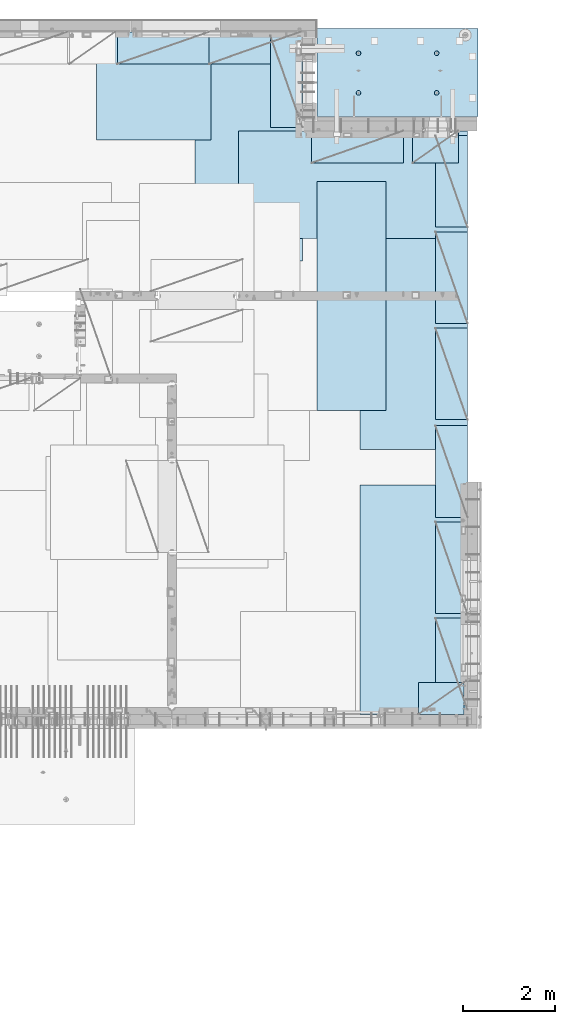
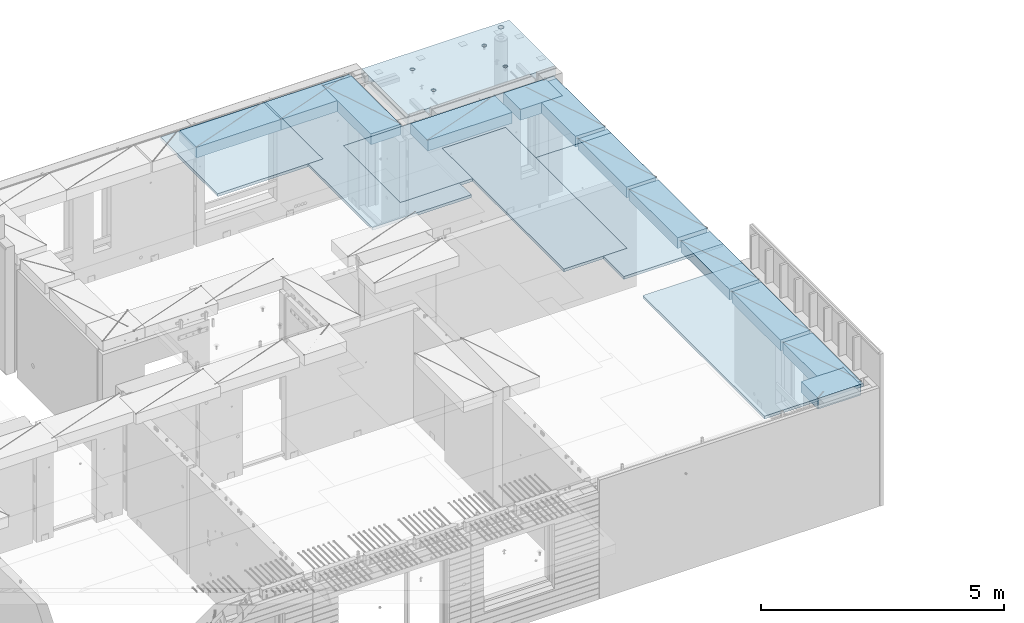
# One storey, part 179 of 309: 18 plates, 1 slab, 19 elements without a shape of their own.
"""IFC2X3 building model written with IfcOpenShell, lengths in millimetres."""

from ifc_helpers import new_model, si_unit, frame, origin_with_axes, place, context, subcontext, project, spatial, faceted_brep, material, type_object, element, aggregate, save


model = new_model("IFC2X3")

# Units and contexts
model_context = context("Model", 3, precision=1e-05, world=origin_with_axes())
body_context = subcontext(model_context, "Body", "Model", "MODEL_VIEW")
ifc_project = project(units=[si_unit("LENGTHUNIT", "METRE", prefix="MILLI"), si_unit("AREAUNIT", "SQUARE_METRE"), si_unit("VOLUMEUNIT", "CUBIC_METRE"), si_unit("MASSUNIT", "GRAM", prefix="KILO"), si_unit("TIMEUNIT", "SECOND"), si_unit("PLANEANGLEUNIT", "RADIAN"), si_unit("SOLIDANGLEUNIT", "STERADIAN"), si_unit("THERMODYNAMICTEMPERATUREUNIT", "DEGREE_CELSIUS"), si_unit("LUMINOUSINTENSITYUNIT", "LUMEN")], contexts=[model_context])

# Site, building, storey
site_placement = place(None, origin_with_axes())
site = spatial("IfcSite", under=ifc_project, at=site_placement, CompositionType="ELEMENT")
building_placement = place(site_placement, origin_with_axes())
building = spatial("IfcBuilding", under=site, at=building_placement, CompositionType="ELEMENT")
storey_placement = place(building_placement, origin_with_axes())
storey = spatial("IfcBuildingStorey", under=building, at=storey_placement, Name="7", CompositionType="ELEMENT", Elevation=0.0)

# Assembly, plate
assembly_1_placement = place(storey_placement, origin_with_axes())
assembly_1 = element("IfcElementAssembly", 1, at=assembly_1_placement, inside=storey, Name="Steel Assembly", AssemblyPlace="NOTDEFINED", PredefinedType="NOTDEFINED")
ifc_material_1 = material()
plate_type_1 = type_object("IfcPlateType", PredefinedType="NOTDEFINED")
plate_1_placement = place(assembly_1_placement, frame((26960.07, 22728.45, 102695.1), z_axis=(1.0, 0.0, 0.0), x_axis=(0.0, -1.0, 0.0)))
plate_1 = element("IfcPlate", 2, at=plate_1_placement, type_object=plate_type_1, material=ifc_material_1, Name="1/2", context=body_context, shape_type="Brep", body=[
    faceted_brep([(0.0, -35.0, 0.0), (0.0, -35.0, 2500.0), (0.0, 35.0, 2500.0), (0.0, 35.0, 0.0), (2349.99951171875, -35.0, 2500.0), (2349.99951171875, 35.0, 2500.0), (2350.0, -35.0, 0.0), (2350.0, 35.0, 0.0)], [[[0, 1, 2, 3]], [[1, 4, 5, 2]], [[4, 6, 7, 5]], [[6, 0, 3, 7]], [[5, 7, 3, 2]], [[6, 4, 1, 0]]]),
])
aggregate(assembly_1, [plate_1])

assembly_2_placement = place(storey_placement, origin_with_axes())
assembly_2 = element("IfcElementAssembly", 3, at=assembly_2_placement, inside=storey, Name="Steel Assembly", AssemblyPlace="NOTDEFINED", PredefinedType="NOTDEFINED")
plate_2_placement = place(assembly_2_placement, frame((31460.0, 22740.0, 102695.1), z_axis=(0.0, -1.0, 0.0), x_axis=(-1.0, 3.00000001838171e-08, 0.0)))
plate_2 = element("IfcPlate", 4, at=plate_2_placement, type_object=plate_type_1, material=ifc_material_1, context=body_context, shape_type="Brep", body=[
    faceted_brep([(0.0, -35.0, 0.0), (0.0, -35.0, 5000.0), (0.0, 35.0, 5000.0), (0.0, 35.0, 0.0), (2349.99951171875, -35.0, 5000.0), (2349.99951171875, 35.0, 5000.0), (2350.0, -35.0, 0.0), (2350.0, 35.0, 0.0)], [[[0, 1, 2, 3]], [[1, 4, 5, 2]], [[4, 6, 7, 5]], [[6, 0, 3, 7]], [[5, 7, 3, 2]], [[6, 4, 1, 0]]]),
])
aggregate(assembly_2, [plate_2])

assembly_3_placement = place(storey_placement, origin_with_axes())
assembly_3 = element("IfcElementAssembly", 5, at=assembly_3_placement, inside=storey, Name="Steel Assembly", AssemblyPlace="NOTDEFINED", PredefinedType="NOTDEFINED")
plate_3_placement = place(assembly_3_placement, frame((35060.0, 12850.0, 102695.1), z_axis=(0.0, -1.0, 0.0), x_axis=(-1.0, 3.00000001838171e-08, 0.0)))
plate_3 = element("IfcPlate", 6, at=plate_3_placement, type_object=plate_type_1, material=ifc_material_1, context=body_context, shape_type="Brep", body=[
    faceted_brep([(0.0, -35.0, 0.0), (0.0, -35.0, 5000.0), (0.0, 35.0, 5000.0), (0.0, 35.0, 0.0), (2349.99951171875, -35.0, 5000.0), (2349.99951171875, 35.0, 5000.0), (2350.0, -35.0, 0.0), (2350.0, 35.0, 0.0)], [[[0, 1, 2, 3]], [[1, 4, 5, 2]], [[4, 6, 7, 5]], [[6, 0, 3, 7]], [[5, 7, 3, 2]], [[6, 4, 1, 0]]]),
])
aggregate(assembly_3, [plate_3])

assembly_4_placement = place(storey_placement, origin_with_axes())
assembly_4 = element("IfcElementAssembly", 7, at=assembly_4_placement, inside=storey, Name="Steel Assembly", AssemblyPlace="NOTDEFINED", PredefinedType="NOTDEFINED")
plate_4_placement = place(assembly_4_placement, frame((35060.0, 18630.0, 102695.1), z_axis=(0.0, -1.0, 0.0), x_axis=(-1.0, 3.00000001838171e-08, 0.0)))
plate_4 = element("IfcPlate", 8, at=plate_4_placement, type_object=plate_type_1, material=ifc_material_1, context=body_context, shape_type="Brep", body=[
    faceted_brep([(0.0, -35.0, 0.0), (0.0, -35.0, 5000.0), (0.0, 35.0, 5000.0), (0.0, 35.0, 0.0), (2349.99951171875, -35.0, 5000.0), (2349.99951171875, 35.0, 5000.0), (2350.0, -35.0, 0.0), (2350.0, 35.0, 0.0)], [[[0, 1, 2, 3]], [[1, 4, 5, 2]], [[4, 6, 7, 5]], [[6, 0, 3, 7]], [[5, 7, 3, 2]], [[6, 4, 1, 0]]]),
])
aggregate(assembly_4, [plate_4])

assembly_5_placement = place(storey_placement, origin_with_axes())
assembly_5 = element("IfcElementAssembly", 9, at=assembly_5_placement, inside=storey, Name="Steel Assembly", AssemblyPlace="NOTDEFINED", PredefinedType="NOTDEFINED")
plate_5_placement = place(assembly_5_placement, frame((30060.0, 20580.0, 102695.1), z_axis=(1.0, 0.0, 0.0), x_axis=(0.0, -1.0, 0.0)))
plate_5 = element("IfcPlate", 10, at=plate_5_placement, type_object=plate_type_1, material=ifc_material_1, context=body_context, shape_type="Brep", body=[
    faceted_brep([(0.0, -35.0, 0.0), (0.0, -35.0, 5000.0), (0.0, 35.0, 5000.0), (0.0, 35.0, 0.0), (2349.99951171875, -35.0, 5000.0), (2349.99951171875, 35.0, 5000.0), (2350.0, -35.0, 0.0), (2350.0, 35.0, 0.0)], [[[0, 1, 2, 3]], [[1, 4, 5, 2]], [[4, 6, 7, 5]], [[6, 0, 3, 7]], [[5, 7, 3, 2]], [[6, 4, 1, 0]]]),
])
aggregate(assembly_5, [plate_5])

assembly_6_placement = place(storey_placement, origin_with_axes())
assembly_6 = element("IfcElementAssembly", 11, at=assembly_6_placement, inside=storey, Name="Steel Assembly", AssemblyPlace="NOTDEFINED", PredefinedType="NOTDEFINED")
plate_type_2 = type_object("IfcPlateType", PredefinedType="NOTDEFINED")
plate_6_placement = place(assembly_6_placement, frame((33275.0000122641, 19480.0, 102695.100000381), z_axis=(0.0, -1.0, 0.0), x_axis=(-1.0, 3.00000001838171e-08, 0.0)))
plate_6 = element("IfcPlate", 12, at=plate_6_placement, type_object=plate_type_2, material=ifc_material_1, context=body_context, shape_type="Brep", body=[
    faceted_brep([(0.0, -35.0, 0.0), (0.0, -35.0, 5000.0), (0.0, 35.0, 5000.0), (0.0, 35.0, 0.0), (1499.99951171875, -35.0, 5000.0), (1499.99951171875, 35.0, 5000.0), (1500.0, -35.0, 0.0), (1500.0, 35.0, 0.0)], [[[0, 1, 2, 3]], [[1, 4, 5, 2]], [[4, 6, 7, 5]], [[6, 0, 3, 7]], [[5, 7, 3, 2]], [[6, 4, 1, 0]]]),
])
aggregate(assembly_6, [plate_6])

assembly_7_placement = place(storey_placement, origin_with_axes())
assembly_7 = element("IfcElementAssembly", 13, at=assembly_7_placement, inside=storey, Name="Steel Assembly", AssemblyPlace="NOTDEFINED", PredefinedType="NOTDEFINED")
plate_type_3 = type_object("IfcPlateType", PredefinedType="NOTDEFINED")
plate_7_placement = place(assembly_7_placement, frame((31420.0, 22740.0001220703, 102595.3), z_axis=(0.0, -1.0, 0.0), x_axis=(-1.0, 3.00000001838171e-08, 0.0)))
plate_7 = element("IfcPlate", 14, at=plate_7_placement, type_object=plate_type_3, material=ifc_material_1, Name="RE1", context=body_context, shape_type="Brep", body=[
    faceted_brep([(1.81898940354586e-12, -135.0, 1.81898940354586e-12), (0.0, -135.0, 699.999999999996), (0.0, 135.0, 699.999999999996), (1.81898940354586e-12, 135.0, 1.81898940354586e-12), (1999.99951171875, -135.0, 699.999999999993), (1999.99951171875, 135.0, 699.999999999993), (2000.0, -135.0, -3.63797880709171e-12), (2000.0, 135.0, -3.63797880709171e-12)], [[[0, 1, 2, 3]], [[1, 4, 5, 2]], [[4, 6, 7, 5]], [[6, 0, 3, 7]], [[5, 7, 3, 2]], [[6, 4, 1, 0]]]),
])
aggregate(assembly_7, [plate_7])

assembly_8_placement = place(storey_placement, origin_with_axes())
assembly_8 = element("IfcElementAssembly", 15, at=assembly_8_placement, inside=storey, Name="Steel Assembly", AssemblyPlace="NOTDEFINED", PredefinedType="NOTDEFINED")
plate_8_placement = place(assembly_8_placement, frame((33985.0, 7849.99999992931, 102595.3), z_axis=(0.0, 1.0, 0.0), x_axis=(1.0, 0.0, 0.0)))
plate_8 = element("IfcPlate", 16, at=plate_8_placement, type_object=plate_type_3, material=ifc_material_1, Name="RE1_1/2", context=body_context, shape_type="Brep", body=[
    faceted_brep([(1.81898940354586e-12, -135.0, 1.81898940354586e-12), (0.0, -135.0, 699.999999999996), (0.0, 135.0, 699.999999999996), (1.81898940354586e-12, 135.0, 1.81898940354586e-12), (999.99951171875, -135.0, 700.0), (999.99951171875, 135.0, 700.0), (1000.0, -135.0, 0.0), (1000.0, 135.0, 0.0)], [[[0, 1, 2, 3]], [[1, 4, 5, 2]], [[4, 6, 7, 5]], [[6, 0, 3, 7]], [[5, 7, 3, 2]], [[6, 4, 1, 0]]]),
])
aggregate(assembly_8, [plate_8])

assembly_9_placement = place(storey_placement, origin_with_axes())
assembly_9 = element("IfcElementAssembly", 17, at=assembly_9_placement, inside=storey, Name="Steel Assembly", AssemblyPlace="NOTDEFINED", PredefinedType="NOTDEFINED")
plate_9_placement = place(assembly_9_placement, frame((35060.0001220703, 14280.0, 102595.3), z_axis=(-1.0, 3.00000001838171e-08, 0.0), x_axis=(0.0, 1.0, 0.0)))
plate_9 = element("IfcPlate", 18, at=plate_9_placement, type_object=plate_type_3, material=ifc_material_1, Name="RE1", context=body_context, shape_type="Brep", body=[
    faceted_brep([(1.81898940354586e-12, -135.0, 1.81898940354586e-12), (0.0, -135.0, 699.999999999996), (0.0, 135.0, 699.999999999996), (1.81898940354586e-12, 135.0, 1.81898940354586e-12), (1999.99951171875, -135.0, 699.999999999993), (1999.99951171875, 135.0, 699.999999999993), (2000.0, -135.0, -3.63797880709171e-12), (2000.0, 135.0, -3.63797880709171e-12)], [[[0, 1, 2, 3]], [[1, 4, 5, 2]], [[4, 6, 7, 5]], [[6, 0, 3, 7]], [[5, 7, 3, 2]], [[6, 4, 1, 0]]]),
])
aggregate(assembly_9, [plate_9])

assembly_10_placement = place(storey_placement, origin_with_axes())
assembly_10 = element("IfcElementAssembly", 19, at=assembly_10_placement, inside=storey, Name="Steel Assembly", AssemblyPlace="NOTDEFINED", PredefinedType="NOTDEFINED")
plate_10_placement = place(assembly_10_placement, frame((35060.0001220703, 16380.0, 102595.3), z_axis=(-1.0, 3.00000001838171e-08, 0.0), x_axis=(0.0, 1.0, 0.0)))
plate_10 = element("IfcPlate", 20, at=plate_10_placement, type_object=plate_type_3, material=ifc_material_1, Name="RE1", context=body_context, shape_type="Brep", body=[
    faceted_brep([(1.81898940354586e-12, -135.0, 1.81898940354586e-12), (0.0, -135.0, 699.999999999996), (0.0, 135.0, 699.999999999996), (1.81898940354586e-12, 135.0, 1.81898940354586e-12), (1999.99951171875, -135.0, 699.999999999993), (1999.99951171875, 135.0, 699.999999999993), (2000.0, -135.0, -3.63797880709171e-12), (2000.0, 135.0, -3.63797880709171e-12)], [[[0, 1, 2, 3]], [[1, 4, 5, 2]], [[4, 6, 7, 5]], [[6, 0, 3, 7]], [[5, 7, 3, 2]], [[6, 4, 1, 0]]]),
])
aggregate(assembly_10, [plate_10])

assembly_11_placement = place(storey_placement, origin_with_axes())
assembly_11 = element("IfcElementAssembly", 21, at=assembly_11_placement, inside=storey, Name="Steel Assembly", AssemblyPlace="NOTDEFINED", PredefinedType="NOTDEFINED")
plate_11_placement = place(assembly_11_placement, frame((35060.0001220703, 18480.0, 102595.3), z_axis=(-1.0, 3.00000001838171e-08, 0.0), x_axis=(0.0, 1.0, 0.0)))
plate_11 = element("IfcPlate", 22, at=plate_11_placement, type_object=plate_type_3, material=ifc_material_1, Name="RE1", context=body_context, shape_type="Brep", body=[
    faceted_brep([(1.81898940354586e-12, -135.0, 1.81898940354586e-12), (0.0, -135.0, 699.999999999996), (0.0, 135.0, 699.999999999996), (1.81898940354586e-12, 135.0, 1.81898940354586e-12), (1999.99951171875, -135.0, 699.999999999993), (1999.99951171875, 135.0, 699.999999999993), (2000.0, -135.0, -3.63797880709171e-12), (2000.0, 135.0, -3.63797880709171e-12)], [[[0, 1, 2, 3]], [[1, 4, 5, 2]], [[4, 6, 7, 5]], [[6, 0, 3, 7]], [[5, 7, 3, 2]], [[6, 4, 1, 0]]]),
])
aggregate(assembly_11, [plate_11])

assembly_12_placement = place(storey_placement, origin_with_axes())
assembly_12 = element("IfcElementAssembly", 23, at=assembly_12_placement, inside=storey, Name="Steel Assembly", AssemblyPlace="NOTDEFINED", PredefinedType="NOTDEFINED")
plate_12_placement = place(assembly_12_placement, frame((35060.0001220703, 12150.0, 102595.3), z_axis=(-1.0, 3.00000001838171e-08, 0.0), x_axis=(0.0, 1.0, 0.0)))
plate_12 = element("IfcPlate", 24, at=plate_12_placement, type_object=plate_type_3, material=ifc_material_1, Name="RE1", context=body_context, shape_type="Brep", body=[
    faceted_brep([(1.81898940354586e-12, -135.0, 1.81898940354586e-12), (0.0, -135.0, 699.999999999996), (0.0, 135.0, 699.999999999996), (1.81898940354586e-12, 135.0, 1.81898940354586e-12), (1999.99951171875, -135.0, 699.999999999993), (1999.99951171875, 135.0, 699.999999999993), (2000.0, -135.0, -3.63797880709171e-12), (2000.0, 135.0, -3.63797880709171e-12)], [[[0, 1, 2, 3]], [[1, 4, 5, 2]], [[4, 6, 7, 5]], [[6, 0, 3, 7]], [[5, 7, 3, 2]], [[6, 4, 1, 0]]]),
])
aggregate(assembly_12, [plate_12])

assembly_13_placement = place(storey_placement, origin_with_axes())
assembly_13 = element("IfcElementAssembly", 25, at=assembly_13_placement, inside=storey, Name="Steel Assembly", AssemblyPlace="NOTDEFINED", PredefinedType="NOTDEFINED")
plate_13_placement = place(assembly_13_placement, frame((35060.0001220703, 10050.0, 102595.3), z_axis=(-1.0, 3.00000001838171e-08, 0.0), x_axis=(0.0, 1.0, 0.0)))
plate_13 = element("IfcPlate", 26, at=plate_13_placement, type_object=plate_type_3, material=ifc_material_1, Name="RE1", context=body_context, shape_type="Brep", body=[
    faceted_brep([(1.81898940354586e-12, -135.0, 1.81898940354586e-12), (0.0, -135.0, 699.999999999996), (0.0, 135.0, 699.999999999996), (1.81898940354586e-12, 135.0, 1.81898940354586e-12), (1999.99951171875, -135.0, 699.999999999993), (1999.99951171875, 135.0, 699.999999999993), (2000.0, -135.0, -3.63797880709171e-12), (2000.0, 135.0, -3.63797880709171e-12)], [[[0, 1, 2, 3]], [[1, 4, 5, 2]], [[4, 6, 7, 5]], [[6, 0, 3, 7]], [[5, 7, 3, 2]], [[6, 4, 1, 0]]]),
])
aggregate(assembly_13, [plate_13])

assembly_14_placement = place(storey_placement, origin_with_axes())
assembly_14 = element("IfcElementAssembly", 27, at=assembly_14_placement, inside=storey, Name="Steel Assembly", AssemblyPlace="NOTDEFINED", PredefinedType="NOTDEFINED")
plate_14_placement = place(assembly_14_placement, frame((35060.0001220703, 7950.0, 102595.3), z_axis=(-1.0, 3.00000001838171e-08, 0.0), x_axis=(0.0, 1.0, 0.0)))
plate_14 = element("IfcPlate", 28, at=plate_14_placement, type_object=plate_type_3, material=ifc_material_1, Name="RE1", context=body_context, shape_type="Brep", body=[
    faceted_brep([(1.81898940354586e-12, -135.0, 1.81898940354586e-12), (0.0, -135.0, 699.999999999996), (0.0, 135.0, 699.999999999996), (1.81898940354586e-12, 135.0, 1.81898940354586e-12), (1999.99951171875, -135.0, 699.999999999993), (1999.99951171875, 135.0, 699.999999999993), (2000.0, -135.0, -3.63797880709171e-12), (2000.0, 135.0, -3.63797880709171e-12)], [[[0, 1, 2, 3]], [[1, 4, 5, 2]], [[4, 6, 7, 5]], [[6, 0, 3, 7]], [[5, 7, 3, 2]], [[6, 4, 1, 0]]]),
])
aggregate(assembly_14, [plate_14])

assembly_15_placement = place(storey_placement, origin_with_axes())
assembly_15 = element("IfcElementAssembly", 29, at=assembly_15_placement, inside=storey, Name="Steel Assembly", AssemblyPlace="NOTDEFINED", PredefinedType="NOTDEFINED")
plate_15_placement = place(assembly_15_placement, frame((33660.0, 20580.0001220703, 102595.3), z_axis=(0.0, -1.0, 0.0), x_axis=(-1.0, 3.00000001838171e-08, 0.0)))
plate_15 = element("IfcPlate", 30, at=plate_15_placement, type_object=plate_type_3, material=ifc_material_1, Name="RE1", context=body_context, shape_type="Brep", body=[
    faceted_brep([(1.81898940354586e-12, -135.0, 1.81898940354586e-12), (0.0, -135.0, 699.999999999996), (0.0, 135.0, 699.999999999996), (1.81898940354586e-12, 135.0, 1.81898940354586e-12), (1999.99951171875, -135.0, 699.999999999993), (1999.99951171875, 135.0, 699.999999999993), (2000.0, -135.0, -3.63797880709171e-12), (2000.0, 135.0, -3.63797880709171e-12)], [[[0, 1, 2, 3]], [[1, 4, 5, 2]], [[4, 6, 7, 5]], [[6, 0, 3, 7]], [[5, 7, 3, 2]], [[6, 4, 1, 0]]]),
])
aggregate(assembly_15, [plate_15])

assembly_16_placement = place(storey_placement, origin_with_axes())
assembly_16 = element("IfcElementAssembly", 31, at=assembly_16_placement, inside=storey, Name="Steel Assembly", AssemblyPlace="NOTDEFINED", PredefinedType="NOTDEFINED")
plate_16_placement = place(assembly_16_placement, frame((34860.0, 20580.0000000707, 102595.3), z_axis=(0.0, -1.0, 0.0), x_axis=(-1.0, 3.00000001838171e-08, 0.0)))
plate_16 = element("IfcPlate", 32, at=plate_16_placement, type_object=plate_type_3, material=ifc_material_1, Name="RE1_1/2", context=body_context, shape_type="Brep", body=[
    faceted_brep([(1.81898940354586e-12, -135.0, 1.81898940354586e-12), (0.0, -135.0, 699.999999999996), (0.0, 135.0, 699.999999999996), (1.81898940354586e-12, 135.0, 1.81898940354586e-12), (999.99951171875, -135.0, 700.0), (999.99951171875, 135.0, 700.0), (1000.0, -135.0, 0.0), (1000.0, 135.0, 0.0)], [[[0, 1, 2, 3]], [[1, 4, 5, 2]], [[4, 6, 7, 5]], [[6, 0, 3, 7]], [[5, 7, 3, 2]], [[6, 4, 1, 0]]]),
])
aggregate(assembly_16, [plate_16])

assembly_17_placement = place(storey_placement, origin_with_axes())
assembly_17 = element("IfcElementAssembly", 33, at=assembly_17_placement, inside=storey, Name="Steel Assembly", AssemblyPlace="NOTDEFINED", PredefinedType="NOTDEFINED")
plate_17_placement = place(assembly_17_placement, frame((31460.0001220703, 20660.0, 102595.3), z_axis=(-1.0, 3.00000001838171e-08, 0.0), x_axis=(0.0, 1.0, 0.0)))
plate_17 = element("IfcPlate", 34, at=plate_17_placement, type_object=plate_type_3, material=ifc_material_1, Name="RE1", context=body_context, shape_type="Brep", body=[
    faceted_brep([(1.81898940354586e-12, -135.0, 1.81898940354586e-12), (0.0, -135.0, 699.999999999996), (0.0, 135.0, 699.999999999996), (1.81898940354586e-12, 135.0, 1.81898940354586e-12), (1999.99951171875, -135.0, 699.999999999993), (1999.99951171875, 135.0, 699.999999999993), (2000.0, -135.0, -3.63797880709171e-12), (2000.0, 135.0, -3.63797880709171e-12)], [[[0, 1, 2, 3]], [[1, 4, 5, 2]], [[4, 6, 7, 5]], [[6, 0, 3, 7]], [[5, 7, 3, 2]], [[6, 4, 1, 0]]]),
])
aggregate(assembly_17, [plate_17])

assembly_18_placement = place(storey_placement, origin_with_axes())
assembly_18 = element("IfcElementAssembly", 35, at=assembly_18_placement, inside=storey, Name="Steel Assembly", AssemblyPlace="NOTDEFINED", PredefinedType="NOTDEFINED")
plate_18_placement = place(assembly_18_placement, frame((29420.0, 22740.0001220703, 102595.3), z_axis=(0.0, -1.0, 0.0), x_axis=(-1.0, 3.00000001838171e-08, 0.0)))
plate_18 = element("IfcPlate", 36, at=plate_18_placement, type_object=plate_type_3, material=ifc_material_1, Name="RE1", context=body_context, shape_type="Brep", body=[
    faceted_brep([(1.81898940354586e-12, -135.0, 1.81898940354586e-12), (0.0, -135.0, 699.999999999996), (0.0, 135.0, 699.999999999996), (1.81898940354586e-12, 135.0, 1.81898940354586e-12), (1999.99951171875, -135.0, 699.999999999993), (1999.99951171875, 135.0, 699.999999999993), (2000.0, -135.0, -3.63797880709171e-12), (2000.0, 135.0, -3.63797880709171e-12)], [[[0, 1, 2, 3]], [[1, 4, 5, 2]], [[4, 6, 7, 5]], [[6, 0, 3, 7]], [[5, 7, 3, 2]], [[6, 4, 1, 0]]]),
])
aggregate(assembly_18, [plate_18])

# Assembly, slab
assembly_19_placement = place(storey_placement, origin_with_axes())
assembly_19 = element("IfcElementAssembly", 37, at=assembly_19_placement, inside=storey, AssemblyPlace="NOTDEFINED", PredefinedType="REINFORCEMENT_UNIT")
ifc_material_2 = material(Name="CONCRETE/C35/45")
slab_type = type_object("IfcSlabType", PredefinedType="NOTDEFINED")
slab_placement = place(assembly_19_placement, frame((31779.9998568132, 20899.9965573523, 102575.0), z_axis=(-1.19799915409591e-06, 0.999999999999282, 0.0), x_axis=(0.999999999999282, 1.19800000174933e-06, 0.0)))
slab = element("IfcSlab", 38, at=slab_placement, type_object=slab_type, material=ifc_material_2, PredefinedType="FLOOR", context=body_context, shape_type="Brep", body=[
    faceted_brep([(2620.44345679515, -110.0, 1327.44477430751), (2634.38188363927, -110.0, 1334.54672302846), (2645.44349246833, -110.0, 1345.6082884076), (2652.54549593937, -110.0, 1359.54668735517), (2654.99270047008, -110.0, 1374.99753226764), (2652.54555663031, -110.0, 1390.44838679261), (2645.44360790936, -110.0, 1404.38681363673), (2634.38204253021, -110.0, 1415.4484224658), (2620.44364358264, -110.0, 1422.55042593684), (2604.99279867017, -110.0, 1424.99763046754), (2589.5419441452, -110.0, 1422.55048662777), (2575.60351730108, -110.0, 1415.44853790682), (2564.54190847202, -110.0, 1404.38697252767), (2557.43990500097, -110.0, 1390.44857358011), (2554.99270047027, -110.0, 1374.99772866764), (2557.43984431004, -110.0, 1359.54687414267), (2564.54179303099, -110.0, 1345.60844729854), (2575.60335841014, -110.0, 1334.54683846948), (2589.54175735771, -110.0, 1327.44483499845), (2604.99260227018, -110.0, 1324.99763046774), (2646.40672475315, -130.0, 1405.08655609315), (2653.67776749127, -130.0, 1390.8162619432), (2635.08178876973, -130.0, 1416.41153656099), (2620.81152318056, -130.0, 1423.68263535277), (2604.99280100827, -130.0, 1426.18810665802), (2589.17406899461, -130.0, 1423.68269748873), (2574.90377484467, -130.0, 1416.41165475061), (2563.57879437682, -130.0, 1405.0867187672), (2556.30769558505, -130.0, 1390.81645317802), (2553.8022242798, -130.0, 1374.99773100574), (2556.30763344908, -130.0, 1359.17899899208), (2563.5786761872, -130.0, 1344.90870484214), (2574.90361217062, -130.0, 1333.58372437429), (2589.17387775979, -130.0, 1326.31262558251), (2604.99259993208, -130.0, 1323.80715427726), (2620.81133194574, -130.0, 1326.31256344655), (2635.08162609568, -130.0, 1333.58360618467), (2646.40660656353, -130.0, 1344.90854216808), (2653.6777053553, -130.0, 1359.17880775726), (2656.18317666055, -130.0, 1374.99752992954), (3505.0, -130.0, 1.02227204479277e-09), (0.0, -130.0, -3.63797880709171e-12), (0.0, 130.0, -1.81898940354586e-12), (3505.0, 130.0, 1.02227204479277e-09), (3505.0, -130.0, 1910.00366210938), (3505.0, 130.0, 1910.00366210938), (0.000373178780137096, -130.0, 1910.00366210938), (0.000373178780137096, 130.0, 1910.00366210938), (3278.54350360826, 130.0, 1805.26900756737), (3265.26962515329, 130.0, 1818.54293816225), (3248.54354641621, 130.0, 1827.0653423275), (3230.00253252125, 130.0, 1830.00198776434), (3211.46150709129, 130.0, 1827.06541515662), (3194.73539487833, 130.0, 1818.54307669148), (3181.46146428346, 130.0, 1805.2691982365), (3172.93906011821, 130.0, 1788.54311949942), (3170.00241468137, 130.0, 1770.00210560446), (3172.93898728908, 130.0, 1751.4610801745), (3181.46132575424, 130.0, 1734.73496796154), (3194.73520420921, 130.0, 1721.46103736667), (3211.46128294629, 130.0, 1712.93863320142), (3230.00229684125, 130.0, 1710.00198776457), (3248.54332227121, 130.0, 1712.93856037229), (3265.26943448417, 130.0, 1721.46089883744), (3278.54336507904, 130.0, 1734.73477729241), (3287.06576924428, 130.0, 1751.46085602949), (3290.00241468113, 130.0, 1770.00186992446), (3287.06584207341, 130.0, 1788.54289535442), (3287.06584207341, -130.0, 1788.54289535442), (3290.00241468113, -130.0, 1770.00186992446), (3278.54350360826, -130.0, 1805.26900756737), (3265.26962515329, -130.0, 1818.54293816225), (3248.54354641621, -130.0, 1827.0653423275), (3230.00253252125, -130.0, 1830.00198776434), (3211.46150709129, -130.0, 1827.06541515662), (3194.73539487833, -130.0, 1818.54307669148), (3181.46146428346, -130.0, 1805.2691982365), (3172.93906011821, -130.0, 1788.54311949942), (3170.00241468137, -130.0, 1770.00210560446), (3172.93898728908, -130.0, 1751.4610801745), (3181.46132575424, -130.0, 1734.73496796154), (3194.73520420921, -130.0, 1721.46103736667), (3211.46128294629, -130.0, 1712.93863320142), (3230.00229684125, -130.0, 1710.00198776457), (3248.54332227121, -130.0, 1712.93856037229), (3265.26943448417, -130.0, 1721.46089883744), (3278.54336507904, -130.0, 1734.73477729241), (3287.06576924428, -130.0, 1751.46085602949), (915.443456827416, -110.0, 1327.44812283643), (929.381883671544, -110.0, 1334.55007155738), (940.443492500606, -110.0, 1345.61163693653), (947.545495971644, -110.0, 1359.55003588409), (949.992700502353, -110.0, 1375.00088079656), (947.545556662582, -110.0, 1390.45173532153), (940.44360794163, -110.0, 1404.39016216566), (929.382042562484, -110.0, 1415.45177099472), (915.443643614915, -110.0, 1422.55377446576), (899.992798702449, -110.0, 1425.00097899646), (884.541944177479, -110.0, 1422.55383515669), (870.603517333351, -110.0, 1415.45188643575), (859.541908504289, -110.0, 1404.3903210566), (852.439905033254, -110.0, 1390.45192210903), (849.992700502546, -110.0, 1375.00107719656), (852.439844342316, -110.0, 1359.55022267159), (859.541793063265, -110.0, 1345.61179582746), (870.603358442411, -110.0, 1334.5501869984), (884.541757389979, -110.0, 1327.44818352737), (899.992602302449, -110.0, 1325.00097899666), (948.677767523539, -130.0, 1390.81961047212), (951.18317669283, -130.0, 1375.00087845847), (941.406724785422, -130.0, 1405.08990462207), (930.08178880201, -130.0, 1416.41488508992), (915.811523212829, -130.0, 1423.68598388169), (899.992801040546, -130.0, 1426.19145518694), (884.174069026885, -130.0, 1423.68604601765), (869.903774876948, -130.0, 1416.41500327954), (858.578794409095, -130.0, 1405.09006729612), (851.307695617317, -130.0, 1390.81980170694), (848.802224312072, -130.0, 1375.00107953466), (851.307633481356, -130.0, 1359.182347521), (858.578676219477, -130.0, 1344.91205337106), (869.903612202892, -130.0, 1333.58707290321), (884.173877792065, -130.0, 1326.31597411143), (899.992599964353, -130.0, 1323.81050280618), (915.81133197801, -130.0, 1326.31591197547), (930.081626127954, -130.0, 1333.58695471359), (941.406606595803, -130.0, 1344.911890697), (948.677705387578, -130.0, 1359.18215628618), (915.441758004057, -110.0, 462.456291784572), (929.380184848189, -110.0, 469.558240505528), (940.441793677252, -110.0, 480.619805884675), (947.543797148286, -110.0, 494.558204832239), (949.991001678995, -110.0, 510.009049744709), (947.543857839224, -110.0, 525.459904269679), (940.441909118272, -110.0, 539.398331113807), (929.380343739125, -110.0, 550.45993994287), (915.441944791557, -110.0, 557.561943413904), (899.991099879091, -110.0, 560.009147944613), (884.540245354121, -110.0, 557.562004104842), (870.601818509993, -110.0, 550.460055383894), (859.54020968093, -110.0, 539.398490004744), (852.438206209896, -110.0, 525.460091057179), (849.991001679187, -110.0, 510.009246144709), (852.438145518958, -110.0, 494.558391619739), (859.54009423991, -110.0, 480.619964775611), (870.601659619057, -110.0, 469.558355946552), (884.540058566621, -110.0, 462.45635247551), (899.990903479094, -110.0, 460.009147944806), (948.676068700181, -130.0, 525.827779420273), (951.181477869472, -130.0, 510.009047406613), (941.405025962067, -130.0, 540.098073570211), (930.080089978652, -130.0, 551.423054038063), (915.809824389475, -130.0, 558.694152829838), (899.991102217187, -130.0, 561.199624135086), (884.172370203531, -130.0, 558.694214965799), (869.90207605359, -130.0, 551.423172227682), (858.577095585741, -130.0, 540.098236244266), (851.305996793959, -130.0, 525.827970655093), (848.800525488714, -130.0, 510.009248482802), (851.305934658001, -130.0, 494.190516469145), (858.576977396118, -130.0, 479.920222319204), (869.901913379534, -130.0, 468.595241851355), (884.172178968707, -130.0, 461.324143059581), (899.990901140998, -130.0, 458.818671754329), (915.809633154651, -130.0, 461.324080923619), (930.079927304596, -130.0, 468.595123661737), (941.404907772445, -130.0, 479.920059645148), (948.676006564223, -130.0, 494.190325234325), (2620.4417580345, -110.0, 462.452943292134), (2634.38018487863, -110.0, 469.554892013086), (2645.44179370769, -110.0, 480.616457392232), (2652.54379717873, -110.0, 494.554856339797), (2654.99100170944, -110.0, 510.005701252267), (2652.54385786967, -110.0, 525.456555777237), (2645.44190914871, -110.0, 539.394982621365), (2634.38034376958, -110.0, 550.456591450427), (2620.44194482201, -110.0, 557.558594921466), (2604.99109990954, -110.0, 560.005799452174), (2589.54024538457, -110.0, 557.558655612404), (2575.60181854044, -110.0, 550.456706891451), (2564.54020971138, -110.0, 539.395141512305), (2557.43820624034, -110.0, 525.456742564736), (2554.99100170963, -110.0, 510.005897652267), (2557.4381455494, -110.0, 494.555043127297), (2564.54009427036, -110.0, 480.616616283172), (2575.6016596495, -110.0, 469.55500745411), (2589.54005859706, -110.0, 462.453003983072), (2604.99090350953, -110.0, 460.005799452367), (2653.67606873062, -130.0, 525.824430927831), (2656.18147789991, -130.0, 510.00569891417), (2646.40502599251, -130.0, 540.094725077772), (2635.08009000909, -130.0, 551.419705545621), (2620.80982441992, -130.0, 558.690804337395), (2604.99110224763, -130.0, 561.196275642647), (2589.17237023397, -130.0, 558.690866473356), (2574.90207608403, -130.0, 551.419823735239), (2563.57709561618, -130.0, 540.094887751824), (2556.30599682441, -130.0, 525.82462216265), (2553.80052551916, -130.0, 510.005899990363), (2556.30593468845, -130.0, 494.187167976703), (2563.57697742656, -130.0, 479.916873826762), (2574.90191340998, -130.0, 468.591893358913), (2589.17217899915, -130.0, 461.320794567138), (2604.99090117144, -130.0, 458.81532326189), (2620.8096331851, -130.0, 461.320732431177), (2635.07992733504, -130.0, 468.591775169294), (2646.40490780289, -130.0, 479.916711152709), (2653.67600659467, -130.0, 494.186976741883)], [[[0, 1, 2, 3, 4, 5, 6, 7, 8, 9, 10, 11, 12, 13, 14, 15, 16, 17, 18, 19]], [[20, 6, 5, 21]], [[22, 7, 6, 20]], [[23, 8, 7, 22]], [[24, 9, 8, 23]], [[25, 10, 9, 24]], [[26, 11, 10, 25]], [[27, 12, 11, 26]], [[28, 13, 12, 27]], [[29, 14, 13, 28]], [[30, 15, 14, 29]], [[31, 16, 15, 30]], [[32, 17, 16, 31]], [[33, 18, 17, 32]], [[34, 19, 18, 33]], [[35, 0, 19, 34]], [[36, 1, 0, 35]], [[37, 2, 1, 36]], [[38, 3, 2, 37]], [[39, 4, 3, 38]], [[21, 5, 4, 39]], [[40, 41, 42, 43]], [[44, 40, 43, 45]], [[46, 44, 45, 47]], [[41, 46, 47, 42]], [[45, 43, 42, 47], [48, 49, 50, 51, 52, 53, 54, 55, 56, 57, 58, 59, 60, 61, 62, 63, 64, 65, 66, 67]], [[68, 67, 66, 69]], [[70, 48, 67, 68]], [[71, 49, 48, 70]], [[72, 50, 49, 71]], [[73, 51, 50, 72]], [[74, 52, 51, 73]], [[75, 53, 52, 74]], [[76, 54, 53, 75]], [[77, 55, 54, 76]], [[78, 56, 55, 77]], [[79, 57, 56, 78]], [[80, 58, 57, 79]], [[81, 59, 58, 80]], [[82, 60, 59, 81]], [[83, 61, 60, 82]], [[84, 62, 61, 83]], [[85, 63, 62, 84]], [[86, 64, 63, 85]], [[87, 65, 64, 86]], [[69, 66, 65, 87]], [[88, 89, 90, 91, 92, 93, 94, 95, 96, 97, 98, 99, 100, 101, 102, 103, 104, 105, 106, 107]], [[108, 93, 92, 109]], [[110, 94, 93, 108]], [[111, 95, 94, 110]], [[112, 96, 95, 111]], [[113, 97, 96, 112]], [[114, 98, 97, 113]], [[115, 99, 98, 114]], [[116, 100, 99, 115]], [[117, 101, 100, 116]], [[118, 102, 101, 117]], [[119, 103, 102, 118]], [[120, 104, 103, 119]], [[121, 105, 104, 120]], [[122, 106, 105, 121]], [[123, 107, 106, 122]], [[124, 88, 107, 123]], [[125, 89, 88, 124]], [[126, 90, 89, 125]], [[127, 91, 90, 126]], [[109, 92, 91, 127]], [[128, 129, 130, 131, 132, 133, 134, 135, 136, 137, 138, 139, 140, 141, 142, 143, 144, 145, 146, 147]], [[148, 133, 132, 149]], [[150, 134, 133, 148]], [[151, 135, 134, 150]], [[152, 136, 135, 151]], [[153, 137, 136, 152]], [[154, 138, 137, 153]], [[155, 139, 138, 154]], [[156, 140, 139, 155]], [[157, 141, 140, 156]], [[158, 142, 141, 157]], [[159, 143, 142, 158]], [[160, 144, 143, 159]], [[161, 145, 144, 160]], [[162, 146, 145, 161]], [[163, 147, 146, 162]], [[164, 128, 147, 163]], [[165, 129, 128, 164]], [[166, 130, 129, 165]], [[167, 131, 130, 166]], [[149, 132, 131, 167]], [[168, 169, 170, 171, 172, 173, 174, 175, 176, 177, 178, 179, 180, 181, 182, 183, 184, 185, 186, 187]], [[188, 173, 172, 189]], [[190, 174, 173, 188]], [[191, 175, 174, 190]], [[192, 176, 175, 191]], [[193, 177, 176, 192]], [[194, 178, 177, 193]], [[195, 179, 178, 194]], [[196, 180, 179, 195]], [[197, 181, 180, 196]], [[198, 182, 181, 197]], [[199, 183, 182, 198]], [[200, 184, 183, 199]], [[201, 185, 184, 200]], [[202, 186, 185, 201]], [[203, 187, 186, 202]], [[204, 168, 187, 203]], [[205, 169, 168, 204]], [[206, 170, 169, 205]], [[207, 171, 170, 206]], [[189, 172, 171, 207]], [[40, 44, 46, 41], [37, 36, 35, 34, 33, 32, 31, 30, 29, 28, 27, 26, 25, 24, 23, 22, 20, 21, 39, 38], [206, 205, 204, 203, 202, 201, 200, 199, 198, 197, 196, 195, 194, 193, 192, 191, 190, 188, 189, 207], [166, 165, 164, 163, 162, 161, 160, 159, 158, 157, 156, 155, 154, 153, 152, 151, 150, 148, 149, 167], [126, 125, 124, 123, 122, 121, 120, 119, 118, 117, 116, 115, 114, 113, 112, 111, 110, 108, 109, 127], [86, 85, 84, 83, 82, 81, 80, 79, 78, 77, 76, 75, 74, 73, 72, 71, 70, 68, 69, 87]]]),
])
aggregate(assembly_19, [slab])

save(model, "model.ifc")
